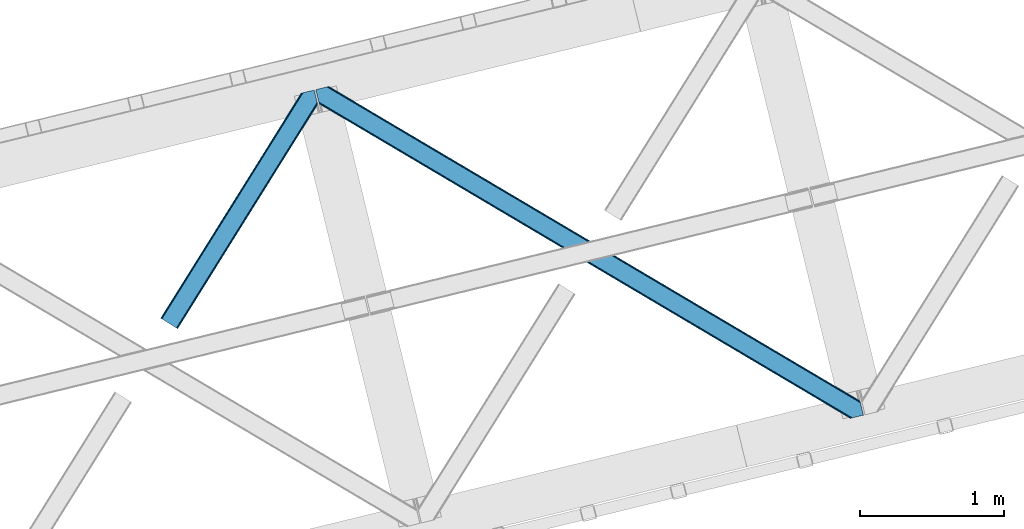
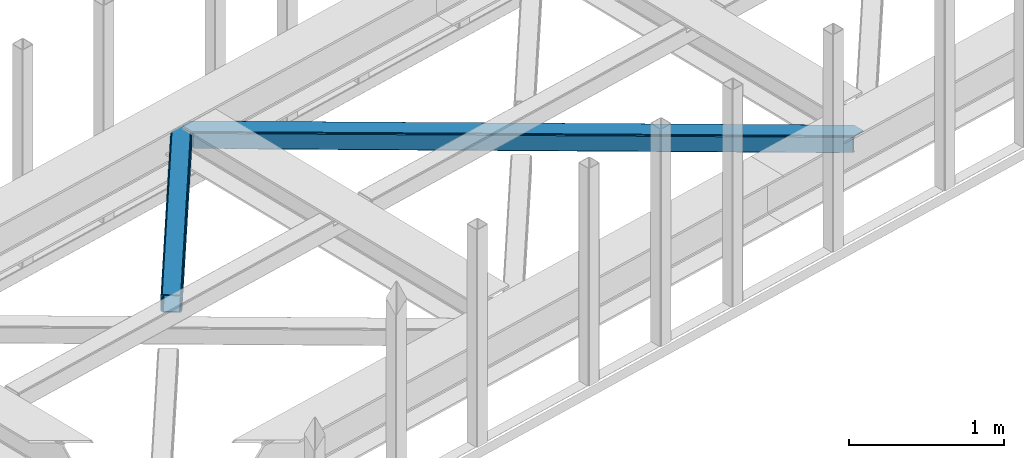
# One storey, part 43 of 67: 2 members.
"""IFC4 building model written with IfcOpenShell, lengths in millimetres."""

from ifc_helpers import new_model, entity, si_unit, converted_unit, derived_unit, direction, frame, origin, place, context, subcontext, project, spatial, triangles, type_object, element, save


model = new_model("IFC4")

# Units and contexts
model_context = context("Model", 3, precision=0.01, world=origin(), true_north=direction((6.12303176911189e-17, 1.0)))
plan_context = context("Plan", 3, precision=0.01, world=origin(), true_north=direction((6.12303176911189e-17, 1.0)))
body_context = subcontext(model_context, "Body", "Model", "MODEL_VIEW")
ifc_project = project(units=[si_unit("LENGTHUNIT", "METRE", prefix="MILLI"), si_unit("AREAUNIT", "SQUARE_METRE"), si_unit("VOLUMEUNIT", "CUBIC_METRE"), converted_unit("PLANEANGLEUNIT", "DEGREE", entity("IfcRatioMeasure", 0.0174532925199433), si_unit("PLANEANGLEUNIT", "RADIAN"), dimensions=[0, 0, 0, 0, 0, 0, 0]), si_unit("MASSUNIT", "GRAM", prefix="KILO"), derived_unit("MASSDENSITYUNIT", [(si_unit("MASSUNIT", "GRAM", prefix="KILO"), 1), (si_unit("LENGTHUNIT", "METRE"), -3)]), derived_unit("MOMENTOFINERTIAUNIT", [(si_unit("LENGTHUNIT", "METRE"), 4)]), si_unit("TIMEUNIT", "SECOND"), si_unit("FREQUENCYUNIT", "HERTZ"), si_unit("THERMODYNAMICTEMPERATUREUNIT", "DEGREE_CELSIUS"), derived_unit("THERMALTRANSMITTANCEUNIT", [(si_unit("MASSUNIT", "GRAM", prefix="KILO"), 1), (si_unit("THERMODYNAMICTEMPERATUREUNIT", "KELVIN"), -1), (si_unit("TIMEUNIT", "SECOND"), -3)]), derived_unit("VOLUMETRICFLOWRATEUNIT", [(si_unit("LENGTHUNIT", "METRE"), 3), (si_unit("TIMEUNIT", "SECOND"), -1)]), derived_unit("MASSFLOWRATEUNIT", [(si_unit("MASSUNIT", "GRAM", prefix="KILO"), 1), (si_unit("TIMEUNIT", "SECOND"), -1)]), derived_unit("ROTATIONALFREQUENCYUNIT", [(si_unit("TIMEUNIT", "SECOND"), -1)]), si_unit("ELECTRICCURRENTUNIT", "AMPERE"), si_unit("ELECTRICVOLTAGEUNIT", "VOLT"), si_unit("POWERUNIT", "WATT"), si_unit("FORCEUNIT", "NEWTON", prefix="KILO"), si_unit("ILLUMINANCEUNIT", "LUX"), si_unit("LUMINOUSFLUXUNIT", "LUMEN"), si_unit("LUMINOUSINTENSITYUNIT", "CANDELA"), derived_unit("USERDEFINED", [(si_unit("MASSUNIT", "GRAM", prefix="KILO"), -1), (si_unit("LENGTHUNIT", "METRE"), -2), (si_unit("TIMEUNIT", "SECOND"), 3), (si_unit("LUMINOUSFLUXUNIT", "LUMEN"), 1)]), derived_unit("LINEARVELOCITYUNIT", [(si_unit("LENGTHUNIT", "METRE"), 1), (si_unit("TIMEUNIT", "SECOND"), -1)]), si_unit("PRESSUREUNIT", "PASCAL"), derived_unit("USERDEFINED", [(si_unit("LENGTHUNIT", "METRE"), -2), (si_unit("MASSUNIT", "GRAM", prefix="KILO"), 1), (si_unit("TIMEUNIT", "SECOND"), -2)]), derived_unit("LINEARFORCEUNIT", [(si_unit("MASSUNIT", "GRAM", prefix="KILO"), 1), (si_unit("LENGTHUNIT", "METRE"), 1), (si_unit("TIMEUNIT", "SECOND"), -2), (si_unit("LENGTHUNIT", "METRE"), -1)]), derived_unit("PLANARFORCEUNIT", [(si_unit("MASSUNIT", "GRAM", prefix="KILO"), 1), (si_unit("LENGTHUNIT", "METRE"), 1), (si_unit("TIMEUNIT", "SECOND"), -2), (si_unit("LENGTHUNIT", "METRE"), -2)])], contexts=[model_context, plan_context])

# Site, building, storey
site_placement = place(None, origin())
site = spatial("IfcSite", under=ifc_project, at=site_placement, CompositionType="ELEMENT")
building_placement = place(site_placement, origin())
building = spatial("IfcBuilding", under=site, at=building_placement, CompositionType="ELEMENT")
storey_placement = place(building_placement, frame((0.0, 0.0, 19800.0)))
storey = spatial("IfcBuildingStorey", under=building, at=storey_placement, CompositionType="ELEMENT", Elevation=19800.0)

# Members
member_type_1 = type_object("IfcMemberType", PredefinedType="BRACE")
member_1_placement = place(storey_placement, frame((-25090.0569030762, 13275.8570983887, 3822.99993896484)))
element("IfcMember", 1, at=member_1_placement, inside=storey, type_object=member_type_1, ObjectType="Steel Horizontal Brace", PredefinedType="BRACE", context=body_context, shape_type="Tessellation", body=[
    triangles([(933.019793701173, 1535.69230957031, 0.0), (967.780462646486, 1393.09171142578, 0.0), (14.8456054687485, 64.8704589843746, 0.0), (103.916912841796, 9.2680389404286, 0.0), (928.803771972656, 1552.99125366211, 5.49966430664063), (928.943298339844, 1552.41687011719, 5.208984375), (930.803649902344, 1544.78710327148, 1.33247680664135), (971.996484374999, 1375.79276733398, 5.49966430664063), (971.856958007811, 1376.36715087891, 5.208984375), (969.996606445311, 1383.99691772461, 1.33247680664135), (972.210424804689, 1375.53813171387, 5.8531311035149), (972.422039794921, 1375.28349609375, 6.20659790039281), (928.913067626952, 1553.56912536621, 5.74383544921875), (972.724346923827, 1375.53813171387, 6.35310058593677), (929.029339599609, 1554.1772277832, 5.9996337890625), (973.026654052734, 1375.79276733398, 6.49960327148438), (929.143286132814, 1554.78416748047, 6.25543212890625), (929.254907226561, 1555.36203918457, 6.49960327148438), (4.34857177734375, 71.4223846435543, 5.12526855468968), (1.13248901367115, 73.4315643310547, 10.8039916992202), (973.359191894531, 1630.84347839355, 10.8039916992202), (976.914788818358, 1631.70970458984, 6.49960327148438), (9.16455688476708, 68.415591430663, 1.33247680664135), (971.508142089842, 1630.39118041992, 17.5012573242202), (0.0, 74.1361724853505, 17.5012573242202), (1081.10145263672, 1548.91708374023, 6.49960327148438), (1056.20762329101, 1651.03759460449, 6.49960327148438), (971.508142089842, 1630.39118041992, 122.499499511719), (0.0, 74.1361724853505, 122.499499511719), (973.359191894531, 1630.84347839355, 129.196765136719), (1.13248901367115, 73.4315643310547, 129.196765136719), (978.633288574219, 1632.12828369141, 134.87548828125), (4.34857177734375, 71.4223846435543, 134.87548828125), (986.525830078124, 1634.05258483887, 138.668280029298), (9.16455688476708, 68.415591430663, 138.668280029298), (995.83921508789, 1636.32221374512, 140.00075683594), (14.8456054687485, 64.8704589843746, 140.00075683594), (118.760192871094, 0.0, 17.5012573242202), (117.630029296874, 0.705770874023074, 10.8039916992202), (1085.14306640625, 1551.25066223144, 10.9783996582046), (1087.41734619141, 1552.56453552246, 13.4991760253906), (109.595635986327, 5.7205810546875, 1.33247680664135), (114.41162109375, 2.71495056152344, 5.12526855468968), (1087.56849975586, 1551.93550415039, 17.5012573242202), (1081.77583007812, 1575.70149536133, 140.00075683594), (1063.00720825195, 1652.69563293457, 140.00075683594), (103.916912841796, 9.2680389404286, 140.00075683594), (1083.99429931641, 1566.60670166016, 138.668280029298), (109.595635986327, 5.7205810546875, 138.668280029298), (1085.87325439453, 1558.89670715332, 134.87548828125), (114.41162109375, 2.71495056152344, 134.87548828125), (1087.12899169922, 1553.74469604492, 129.196765136719), (117.630029296874, 0.705770874023074, 129.196765136719), (1087.56849975586, 1551.93550415039, 122.499499511719), (118.760192871094, 0.0, 122.499499511719), (1082.53857421875, 1566.77297058105, 12.1248413085959), (1083.96406860352, 1566.72413635254, 13.4991760253906), (1077.85048828125, 1569.98556518555, 8.3320495605476), (1074.6483581543, 1577.50138549805, 6.99957275390625), (1056.69364013672, 1651.1561920166, 6.99957275390625), (1005.57350463867, 1638.69532470703, 6.99957275390625), (20.784777832032, 61.1625457763657, 6.99957275390625), (97.9754150390618, 12.9736267089829, 6.99957275390625), (108.47244873047, 6.42053833007776, 12.1248413085959), (111.690856933594, 4.41252136230469, 17.8035644531265), (1084.81052856445, 1563.2510925293, 17.8035644531265), (103.656463623047, 9.42733154296729, 8.3320495605476), (1085.25236206055, 1561.44190063477, 24.5008300781265), (112.823345947265, 3.70675048827979, 24.5008300781265), (983.093481445314, 1633.21542663574, 17.8035644531265), (981.24010620117, 1632.76429138184, 24.5008300781265), (7.0693359375, 69.7248138427731, 17.8035644531265), (5.93917236327979, 70.4305847167961, 24.5008300781265), (988.365252685548, 1634.50139465332, 12.1248413085959), (10.2877441406235, 67.7156341552727, 12.1248413085959), (996.262445068358, 1636.42569580078, 8.3320495605476), (15.1037292480469, 64.7100036621086, 8.3320495605476), (981.24010620117, 1632.76429138184, 115.499926757813), (5.93917236327979, 70.4305847167961, 115.499926757813), (996.262445068358, 1636.42569580078, 131.668707275392), (1005.57350463867, 1638.69532470703, 133.001184082033), (1063.00720825195, 1652.69563293457, 133.001184082033), (988.365252685548, 1634.50139465332, 127.873590087893), (983.093481445314, 1633.21542663574, 122.197192382813), (20.784777832032, 61.1625457763657, 133.001184082033), (15.1037292480469, 64.7100036621086, 131.668707275392), (10.2877441406235, 67.7156341552727, 127.873590087893), (7.0693359375, 69.7248138427731, 122.197192382813), (108.47244873047, 6.42053833007776, 127.873590087893), (111.690856933594, 4.41252136230469, 122.197192382813), (112.823345947265, 3.70675048827979, 115.499926757813), (97.9754150390618, 12.9736267089829, 133.001184082033), (103.656463623047, 9.42733154296729, 131.668707275392), (1085.25236206055, 1561.44190063477, 115.499926757813), (1084.81052856445, 1563.2510925293, 122.197192382813), (1083.55479125976, 1568.40310363769, 127.873590087893), (1081.67583618164, 1576.11309814453, 131.668707275392), (1079.45969238281, 1585.20905456543, 133.001184082033)], [[1, 2, 3], [4, 3, 2], [1, 5, 2], [6, 5, 1], [1, 7, 6], [2, 5, 8], [8, 9, 2], [10, 2, 9], [11, 8, 5], [12, 11, 13], [14, 12, 15], [16, 14, 17], [17, 18, 16], [15, 17, 14], [13, 15, 12], [5, 13, 11], [17, 19, 18], [19, 17, 15], [13, 19, 15], [19, 13, 5], [5, 6, 19], [20, 21, 18], [18, 19, 20], [21, 22, 18], [19, 6, 7], [7, 1, 23], [3, 23, 1], [7, 23, 19], [24, 21, 20], [20, 25, 24], [18, 26, 16], [26, 18, 22], [27, 26, 22], [28, 24, 25], [25, 29, 28], [30, 28, 31], [29, 31, 28], [32, 30, 33], [31, 33, 30], [34, 32, 35], [33, 35, 32], [36, 34, 37], [35, 37, 34], [38, 39, 40], [40, 41, 38], [42, 10, 9], [39, 12, 16], [16, 40, 39], [16, 26, 40], [9, 39, 43], [9, 12, 39], [9, 43, 42], [2, 10, 4], [42, 4, 10], [41, 44, 38], [45, 36, 37], [36, 45, 46], [37, 47, 45], [48, 45, 47], [47, 49, 48], [50, 48, 49], [49, 51, 50], [52, 50, 51], [51, 53, 52], [54, 52, 53], [53, 55, 54], [44, 54, 38], [55, 38, 54], [56, 40, 26], [41, 40, 56], [56, 57, 41], [58, 26, 59], [26, 58, 56], [60, 59, 26], [59, 61, 62], [61, 59, 60], [62, 63, 59], [64, 65, 66], [66, 57, 64], [58, 59, 63], [63, 67, 58], [56, 58, 67], [67, 64, 56], [57, 56, 64], [68, 66, 65], [65, 69, 68], [70, 71, 72], [73, 72, 71], [74, 70, 75], [72, 75, 70], [76, 74, 77], [75, 77, 74], [61, 76, 62], [77, 62, 76], [71, 78, 73], [79, 73, 78], [34, 36, 80], [46, 81, 36], [81, 46, 82], [81, 80, 36], [83, 34, 80], [83, 32, 34], [32, 84, 30], [84, 32, 83], [28, 84, 78], [84, 28, 30], [61, 22, 76], [70, 74, 22], [74, 76, 22], [61, 60, 22], [71, 70, 24], [21, 24, 70], [28, 71, 24], [71, 28, 78], [70, 22, 21], [80, 81, 85], [85, 86, 80], [83, 80, 86], [86, 87, 83], [84, 83, 87], [87, 88, 84], [78, 84, 88], [88, 79, 78], [53, 89, 90], [91, 38, 55], [53, 90, 55], [53, 51, 89], [90, 91, 55], [89, 51, 49], [92, 47, 37], [47, 93, 49], [93, 47, 92], [93, 89, 49], [39, 64, 43], [69, 38, 91], [38, 65, 39], [65, 38, 69], [39, 65, 64], [4, 63, 3], [42, 43, 64], [64, 67, 42], [67, 63, 4], [4, 42, 67], [87, 35, 33], [37, 85, 92], [37, 86, 85], [86, 37, 35], [87, 86, 35], [79, 29, 25], [31, 88, 87], [33, 31, 87], [88, 31, 29], [79, 88, 29], [23, 75, 19], [3, 63, 62], [62, 77, 3], [77, 75, 23], [23, 3, 77], [20, 19, 75], [25, 73, 79], [72, 25, 20], [25, 72, 73], [72, 20, 75], [66, 41, 57], [54, 44, 68], [44, 66, 68], [68, 94, 54], [44, 41, 66], [95, 54, 94], [52, 54, 95], [50, 95, 96], [95, 50, 52], [96, 48, 50], [97, 48, 96], [97, 98, 45], [97, 45, 48], [98, 46, 45], [98, 82, 46], [81, 98, 85], [81, 82, 98], [92, 85, 98], [95, 94, 90], [91, 90, 94], [96, 95, 89], [90, 89, 95], [97, 96, 93], [89, 93, 96], [98, 97, 92], [93, 92, 97], [94, 68, 69], [69, 91, 94]]),
])
member_type_2 = type_object("IfcMemberType", PredefinedType="BRACE")
member_2_placement = place(storey_placement, frame((-24015.3899414063, 12655.9240081787, 3822.99993896484)))
element("IfcMember", 2, at=member_2_placement, inside=storey, type_object=member_type_2, ObjectType="Steel Horizontal Brace", PredefinedType="BRACE", context=body_context, shape_type="Tessellation", body=[
    triangles([(3167.12528686523, 476.930191040039, 17.5012573242202), (3764.84926757812, 123.064581298828, 122.499499511719), (3764.84926757812, 123.064581298828, 17.5012573242202), (2547.33288574219, 843.861282348633, 17.5012573242202), (1927.54048461914, 1210.79353637695, 17.5012573242202), (91.5013916015632, 2297.7748626709, 122.499499511719), (687.9580078125, 1944.65804443359, 17.5012573242202), (91.5013916015632, 2297.7748626709, 17.5012573242202), (1307.7480834961, 1577.72579040527, 17.5012573242202), (3770.64193725586, 99.297427368163, 140.00075683594), (3768.42346801758, 108.393383789062, 138.668280029298), (76.4813781738267, 2294.11345825195, 138.668280029298), (67.167993164061, 2291.8438293457, 140.00075683594), (3766.54451293945, 116.103378295898, 134.87548828125), (84.3739196777351, 2296.03775939941, 134.87548828125), (3765.28877563477, 121.255389404296, 129.196765136719), (89.6503417968743, 2297.32372741699, 129.196765136719), (3722.24024047852, 5.93103332519422, 140.00075683594), (18.7662963867188, 2198.47743530273, 140.00075683594), (3789.41055908203, 22.304452514647, 140.00075683594), (0.0, 2275.47041015625, 140.00075683594), (3697.90916748047, 0.0, 122.499499511719), (3699.76021728515, 0.451135253904795, 129.196765136719), (24.1194580078118, 2176.5194732666, 129.196765136719), (24.5612915039055, 2174.71028137207, 122.499499511719), (3705.03431396484, 1.73710327148365, 134.87548828125), (22.8637207031243, 2181.671484375, 134.87548828125), (3712.9291809082, 3.66024169921729, 138.668280029298), (20.9847656249985, 2189.38147888184, 138.668280029298), (1862.08401489258, 1086.85342712402, 17.5012573242202), (2481.93687744141, 719.881640624999, 17.5012573242202), (3101.79671630859, 352.912179565428, 17.5012573242202), (3697.90916748047, 0.0, 17.5012573242202), (1242.22417602539, 1453.82288818359, 17.5012573242202), (622.368988037109, 1820.79467468262, 17.5012573242202), (24.5612915039055, 2174.71028137207, 17.5012573242202), (74.641955566407, 2293.66581115723, 127.873590087893), (66.7470886230476, 2291.74151000977, 131.668707275392), (79.9160522460952, 2294.9517791748, 122.197192382813), (57.433703613282, 2289.47071838379, 133.001184082033), (0.0, 2275.47041015625, 133.001184082033), (81.7671020507805, 2295.40175170898, 115.499926757813), (81.7671020507805, 2295.40175170898, 24.5008300781265), (79.9160522460952, 2294.9517791748, 17.8035644531265), (89.5619750976548, 2297.30279846191, 10.8156188964858), (89.4689575195298, 2297.27954406738, 10.4993591308594), (74.1140808105483, 2293.53674926758, 12.4271484375022), (72.0351379394524, 2293.0298034668, 10.4993591308594), (1922.1942993164, 1205.8275604248, 24.5008300781265), (3767.16540527344, 113.558184814452, 115.499926757813), (2545.10744018555, 837.044256591797, 24.5008300781265), (3168.02755737305, 468.263278198241, 24.5008300781265), (3767.16540527344, 113.558184814452, 24.5008300781265), (1299.27418212891, 1574.60853881836, 24.5008300781265), (676.358715820312, 1943.39067993164, 24.5008300781265), (3767.60723876953, 111.748992919922, 122.197192382813), (3768.86297607422, 106.596981811523, 127.873590087893), (3770.74193115234, 98.8858245849606, 131.668707275392), (3772.95807495117, 89.7910308837891, 133.001184082033), (3767.69560546875, 111.385061645507, 17.8686767578147), (3767.80257568359, 110.943228149414, 16.5199218750022), (3764.85624389648, 123.027374267578, 16.5199218750022), (3789.41055908203, 22.304452514647, 133.001184082033), (3731.9745300293, 8.30298156738172, 133.001184082033), (16.4501586914048, 2207.98383178711, 133.001184082033), (162.736578369142, 2253.90428466797, 10.4993591308594), (166.88748779297, 2236.87509155273, 10.4993591308594), (3722.66114501953, 6.03335266113208, 131.668707275392), (18.6663024902336, 2198.88787536621, 131.668707275392), (3714.76627807617, 4.10905151367115, 127.873590087893), (20.5452575683594, 2191.17788085938, 127.873590087893), (3709.49450683594, 2.82424621581958, 122.197192382813), (21.8033203125015, 2186.02586975098, 122.197192382813), (3707.6411315918, 2.3719482421875, 115.499926757813), (22.2428283691406, 2184.21667785644, 115.499926757813), (3114.18665771484, 353.712130737304, 24.5008300781265), (3707.6411315918, 2.3719482421875, 24.5008300781265), (2491.11771240235, 722.582638549804, 24.5008300781265), (1868.0510925293, 1091.4531463623, 24.5008300781265), (621.917852783205, 1829.19532470703, 24.5008300781265), (22.2428283691406, 2184.21667785644, 24.5008300781265), (1244.9867980957, 1460.32481689453, 24.5008300781265), (3709.49450683594, 2.82424621581958, 17.8035644531265), (3700.13228759765, 0.541827392577034, 10.8691040039084), (3700.58342285156, 0.651123046875, 9.52034912109593), (3714.76627807617, 4.10905151367115, 12.1248413085959), (3719.39390258789, 5.23688964843677, 9.52034912109593), (21.7823913574211, 2186.11074829102, 17.817517089843), (21.7591369628899, 2186.20144042969, 17.5012573242202), (32.1375732421875, 2171.84650268555, 10.8179443359368), (28.3471069335938, 2188.73849487305, 10.4993591308594), (27.0099792480469, 2187.35020751953, 12.1248413085959), (32.4980163574219, 2171.71046447754, 10.4993591308594), (203.964294433594, 2084.76809692383, 10.4993591308594), (208.115203857422, 2067.73890380859, 10.4993591308594), (164.09696044922, 2252.54739074707, 9.49942016601563), (168.582733154297, 2234.14386291504, 9.49942016601563), (168.164154052734, 2234.81707763672, 9.74591674804833), (163.769073486328, 2252.87527770996, 9.74126586914281), (167.733947753906, 2235.50889587402, 9.9993896484375), (163.415606689454, 2253.22525634766, 9.9993896484375), (167.306066894533, 2236.20187683105, 10.2528625488303), (163.064465332031, 2253.57639770508, 10.2598388671868), (209.161651611328, 2067.67146606445, 9.49942016601563), (209.136071777342, 2067.46682739258, 9.88311767578125), (204.678204345702, 2085.44247436523, 9.8528869628899), (208.801208496094, 2067.5551940918, 10.0831054687515), (204.682855224608, 2084.81111755371, 10.2063537597678), (208.447741699219, 2067.65053710938, 10.2993713378928), (204.322412109374, 2084.78902587891, 10.3528564453118), (204.675878906251, 2086.07383117676, 9.49942016601563), (3763.57492675781, 109.725860595703, 12.1248413085959), (3758.56825561524, 124.970278930663, 10.8714294433594), (3757.06602172851, 125.435366821288, 9.52034912109593), (3761.54481811524, 107.063232421875, 9.52034912109593), (3585.92530517578, 211.033630371094, 9.52034912109593), (3581.44650878906, 229.405764770507, 9.52034912109593), (3585.50672607422, 211.133624267577, 9.44360961914208), (3581.04653320312, 229.55343017578, 9.37384643554833), (3580.64655761719, 229.699932861327, 9.22734375000073), (3580.53493652344, 229.532501220703, 8.87387695312646), (3585.4578918457, 210.476687622069, 9.13897705078125), (3580.42796630859, 229.365069580077, 8.52041015625218), (3585.40673217773, 209.805798339843, 8.82736816406396), (3585.35557250976, 209.147698974608, 8.52041015625218), (3164.51381835937, 472.51883239746, 5.12526855468968), (3581.30233154297, 225.771102905273, 5.12526855468968), (3166.44858398438, 475.783749389648, 10.8039916992202), (687.281304931639, 1943.5116027832, 10.8039916992202), (685.34653930664, 1940.24784851074, 5.12526855468968), (165.152709960938, 2248.2150970459, 5.12526855468968), (682.456018066405, 1935.36210021973, 1.33247680664135), (167.031665039063, 2240.50393981933, 1.33247680664135), (679.044598388671, 1929.59966125488, 0.0), (169.247808837892, 2231.40914611816, 0.0), (3583.18361206055, 218.061108398437, 1.33247680664135), (3585.39975585938, 208.965151977538, 0.0), (3158.2118774414, 461.8706451416, 0.0), (3161.62329711914, 467.633084106445, 1.33247680664135), (2546.65618286133, 842.716003417969, 10.8039916992202), (1926.86378173828, 1209.64709472656, 10.8039916992202), (1307.07138061523, 1576.57934875488, 10.8039916992202), (2544.72141723633, 839.451086425781, 5.12526855468968), (1924.92901611328, 1206.3833404541, 5.12526855468968), (1305.13661499024, 1573.31443176269, 5.12526855468968), (2541.83089599609, 834.565338134766, 1.33247680664135), (1922.03849487305, 1201.49759216308, 1.33247680664135), (1302.24609375, 1568.42984619141, 1.33247680664135), (2538.41947631836, 828.802899169921, 0.0), (1918.62707519531, 1195.73515319824, 0.0), (1298.83467407227, 1562.66740722656, 0.0), (3620.16042480469, 66.3657165527329, 0.0), (3110.71245117188, 367.97056274414, 0.0), (2490.85726318359, 734.941186523436, 0.0), (1870.99742431641, 1101.91181030273, 0.0), (631.284722900389, 1835.85305786133, 0.0), (1251.13758544922, 1468.8812713623, 0.0), (204.008477783202, 2088.80854797363, 0.0), (3167.34852905274, 467.116836547852, 17.8035644531265), (3165.41608886719, 463.853082275389, 12.1248413085959), (673.749572753906, 1938.98048400879, 12.1248413085959), (675.682012939455, 1942.24423828125, 17.8035644531265), (670.85672607422, 1934.09473571777, 8.3320495605476), (169.396636962891, 2230.80104370117, 8.81806640624927), (171.566271972657, 2221.90274963379, 6.99957275390625), (3159.11182250977, 453.204895019531, 6.99957275390625), (3587.71821899414, 199.458755493164, 6.99957275390625), (3585.50672607422, 208.524481201172, 8.42274169921802), (3162.5232421875, 458.967333984374, 8.3320495605476), (667.442980957032, 1928.3311340332, 6.99957275390625), (2536.19403076172, 821.985873413085, 6.99957275390625), (2539.60545043945, 827.748312377929, 8.3320495605476), (1913.27856445313, 1190.76801452637, 6.99957275390625), (1916.68998413086, 1196.53045349121, 8.3320495605476), (1290.36077270508, 1559.54899291992, 6.99957275390625), (1293.76986694336, 1565.31259460449, 8.3320495605476), (2542.49597167969, 832.634060668945, 12.1248413085959), (1919.58283081055, 1201.41620178223, 12.1248413085959), (1296.66271362305, 1570.19718017578, 12.1248413085959), (2544.43073730469, 835.898977661132, 17.8035644531265), (1921.51527099609, 1204.68111877441, 17.8035644531265), (1298.59515380859, 1573.46209716797, 17.8035644531265), (201.692340087891, 2098.31610717773, 6.99957275390625), (203.861975097658, 2089.41665039063, 8.81806640624927), (206.226947021485, 2079.71375427246, 1.33247680664135), (208.105902099611, 2072.00375976562, 5.12526855468968), (2500.03577270508, 737.642184448241, 6.99957275390625), (3123.10239257813, 368.771676635741, 6.99957275390625), (1876.96682739258, 1106.51269226074, 6.99957275390625), (3617.84196166992, 75.8721130371086, 6.99957275390625), (630.833587646484, 1844.25370788574, 6.99957275390625), (1253.90020751953, 1475.38320007324, 6.99957275390625), (3119.69097290039, 363.009237670898, 8.3320495605476), (3620.56040039063, 65.0390533447262, 8.90410766601781), (3620.2046081543, 66.183169555663, 8.52041015625218), (3116.7981262207, 358.123489379883, 12.1248413085959), (3621.05106811523, 64.3204925537102, 9.1087463378899), (3621.5487121582, 63.5914672851559, 9.31571044922021), (3622.04170532227, 62.8729064941399, 9.52034912109593), (3620.05345458984, 66.8063873291012, 8.42274169921802), (624.529321289061, 1833.60552062988, 12.1248413085959), (627.422167968751, 1838.4912689209, 8.3320495605476), (622.596881103516, 1830.34176635742, 17.8035644531265), (3114.86568603515, 354.858572387695, 17.8035644531265), (2491.79906616211, 723.730242919921, 17.8035644531265), (1868.73012084961, 1092.59958801269, 17.8035644531265), (1245.66350097656, 1461.47125854492, 17.8035644531265), (2493.72685546875, 726.992834472656, 12.1248413085959), (1870.66256103515, 1095.86450500488, 12.1248413085959), (1247.59594116211, 1464.73501281738, 12.1248413085959), (2496.61970214844, 731.878582763671, 8.3320495605476), (1873.55540771484, 1100.74909057617, 8.3320495605476), (1250.4887878418, 1469.6207611084, 8.3320495605476), (3102.47574462891, 354.057458496092, 10.8039916992202), (624.980456542969, 1825.20487060547, 5.12526855468968), (623.048016357421, 1821.93995361328, 10.8039916992202), (3626.51817626953, 44.5007720947251, 9.52034912109593), (3104.40818481445, 357.32237548828, 5.12526855468968), (3624.25552368164, 49.5597656249993, 5.12526855468968), (3625.13221435547, 45.9657989501939, 8.52041015625218), (3625.82286987305, 45.2332855224595, 9.02037963867406), (3622.37656860351, 57.2697601318359, 1.33247680664135), (3107.30103149414, 362.208123779295, 1.33247680664135), (627.873303222656, 1830.09061889648, 1.33247680664135), (2487.44119262695, 729.177584838866, 1.33247680664135), (1867.58600463867, 1096.14937133789, 1.33247680664135), (1247.72849121094, 1463.11883239746, 1.33247680664135), (2484.55299682617, 724.292999267578, 5.12526855468968), (1864.69315795898, 1091.26362304687, 5.12526855468968), (1244.83564453125, 1458.23308410644, 5.12526855468968), (2482.62055664062, 721.029244995116, 10.8039916992202), (1862.76071777344, 1087.99870605469, 10.8039916992202), (1242.9032043457, 1454.96932983398, 10.8039916992202)], [[1, 2, 3], [2, 1, 4], [2, 5, 6], [5, 2, 4], [7, 8, 6], [9, 6, 5], [6, 9, 7], [10, 11, 12], [12, 13, 10], [11, 14, 15], [15, 12, 11], [14, 16, 17], [17, 15, 14], [16, 2, 6], [6, 17, 16], [18, 10, 19], [18, 20, 10], [13, 19, 10], [21, 19, 13], [22, 23, 24], [24, 25, 22], [23, 26, 27], [27, 24, 23], [26, 28, 29], [29, 27, 26], [28, 18, 19], [19, 29, 28], [30, 22, 25], [22, 31, 32], [30, 31, 22], [32, 33, 22], [34, 25, 35], [25, 34, 30], [36, 35, 25], [37, 38, 12], [15, 37, 12], [15, 17, 39], [37, 15, 39], [39, 17, 6], [38, 13, 12], [21, 40, 41], [21, 13, 40], [38, 40, 13], [39, 6, 42], [43, 8, 44], [6, 43, 42], [8, 45, 44], [6, 8, 43], [46, 44, 45], [46, 47, 44], [46, 48, 47], [49, 50, 42], [50, 51, 52], [49, 51, 50], [52, 53, 50], [54, 42, 55], [42, 54, 49], [43, 55, 42], [50, 56, 42], [39, 42, 56], [56, 57, 39], [37, 39, 57], [57, 58, 37], [38, 37, 58], [58, 59, 38], [40, 38, 59], [57, 14, 11], [59, 58, 10], [58, 57, 11], [60, 61, 62], [63, 59, 20], [10, 20, 59], [58, 11, 10], [60, 3, 53], [2, 50, 53], [53, 3, 2], [60, 62, 3], [2, 56, 50], [56, 14, 57], [14, 56, 16], [2, 16, 56], [59, 64, 65], [64, 59, 63], [65, 40, 59], [41, 40, 65], [66, 67, 46], [48, 46, 67], [64, 68, 65], [69, 65, 68], [68, 70, 69], [71, 69, 70], [70, 72, 71], [73, 71, 72], [72, 74, 73], [75, 73, 74], [76, 74, 77], [74, 76, 78], [74, 79, 75], [79, 74, 78], [80, 81, 75], [82, 75, 79], [75, 82, 80], [70, 68, 28], [26, 70, 28], [26, 23, 72], [70, 26, 72], [72, 23, 22], [68, 18, 28], [20, 64, 63], [20, 18, 64], [68, 64, 18], [72, 22, 74], [77, 33, 83], [22, 77, 74], [33, 84, 83], [22, 33, 77], [85, 83, 84], [86, 83, 85], [87, 86, 85], [73, 75, 25], [25, 24, 73], [27, 73, 24], [73, 27, 71], [25, 81, 36], [88, 89, 36], [36, 81, 88], [75, 81, 25], [69, 29, 19], [21, 65, 19], [41, 65, 21], [69, 71, 29], [29, 71, 27], [65, 69, 19], [90, 91, 92], [90, 93, 91], [92, 36, 90], [89, 36, 92], [94, 95, 93], [93, 91, 94], [96, 97, 98], [98, 99, 96], [99, 98, 100], [100, 101, 99], [101, 100, 102], [102, 103, 101], [103, 102, 67], [67, 66, 103], [104, 105, 106], [105, 107, 108], [108, 107, 109], [110, 109, 95], [95, 94, 110], [109, 110, 108], [108, 106, 105], [106, 111, 104], [62, 112, 113], [112, 62, 61], [112, 114, 113], [112, 115, 114], [114, 115, 116], [116, 117, 114], [118, 119, 117], [120, 119, 118], [121, 120, 122], [123, 121, 124], [124, 125, 123], [122, 124, 121], [118, 122, 120], [117, 116, 118], [1, 3, 113], [3, 62, 113], [120, 121, 126], [123, 126, 121], [123, 127, 126], [128, 113, 117], [117, 126, 128], [117, 119, 126], [120, 126, 119], [113, 114, 117], [45, 129, 66], [129, 130, 131], [131, 96, 129], [129, 99, 101], [99, 129, 96], [129, 103, 66], [103, 129, 101], [129, 45, 8], [8, 7, 129], [66, 46, 45], [130, 132, 133], [133, 131, 130], [132, 134, 135], [135, 133, 132], [136, 137, 138], [138, 139, 136], [127, 136, 139], [139, 126, 127], [113, 128, 1], [1, 128, 140], [140, 4, 1], [4, 140, 5], [141, 5, 140], [5, 141, 142], [142, 9, 5], [9, 142, 129], [129, 7, 9], [128, 126, 140], [143, 140, 126], [140, 143, 141], [144, 141, 143], [141, 144, 145], [145, 142, 141], [142, 145, 130], [130, 129, 142], [126, 139, 146], [146, 143, 126], [143, 146, 147], [147, 144, 143], [144, 147, 145], [148, 145, 147], [145, 148, 130], [132, 130, 148], [139, 138, 146], [149, 146, 138], [146, 149, 147], [150, 147, 149], [147, 150, 148], [151, 148, 150], [148, 151, 134], [134, 132, 148], [137, 152, 153], [138, 153, 154], [153, 138, 137], [149, 155, 150], [154, 149, 138], [149, 154, 155], [156, 134, 151], [150, 157, 151], [157, 150, 155], [157, 156, 151], [158, 134, 156], [135, 134, 158], [159, 160, 112], [112, 61, 159], [159, 60, 53], [161, 162, 44], [98, 163, 100], [98, 97, 163], [163, 102, 100], [163, 67, 102], [97, 164, 163], [161, 47, 67], [67, 163, 161], [47, 48, 67], [163, 164, 165], [166, 167, 168], [160, 118, 116], [116, 112, 160], [116, 115, 112], [169, 168, 125], [125, 160, 169], [124, 122, 160], [122, 118, 160], [160, 125, 124], [168, 169, 166], [165, 170, 163], [44, 47, 161], [162, 55, 43], [43, 44, 162], [53, 52, 159], [61, 60, 159], [166, 169, 171], [172, 171, 169], [171, 172, 173], [174, 173, 172], [173, 174, 175], [176, 175, 174], [175, 176, 163], [163, 170, 175], [169, 160, 177], [177, 172, 169], [172, 177, 178], [178, 174, 172], [174, 178, 179], [179, 176, 174], [176, 179, 163], [161, 163, 179], [160, 159, 177], [180, 177, 159], [177, 180, 178], [181, 178, 180], [178, 181, 179], [182, 179, 181], [179, 182, 162], [162, 161, 179], [159, 52, 180], [51, 180, 52], [180, 51, 49], [49, 181, 180], [181, 49, 182], [54, 182, 49], [182, 54, 162], [55, 162, 54], [97, 131, 133], [135, 97, 133], [165, 164, 135], [165, 135, 183], [131, 97, 96], [135, 164, 97], [183, 158, 184], [158, 185, 111], [158, 183, 135], [186, 111, 185], [158, 111, 184], [186, 104, 111], [187, 188, 166], [166, 171, 187], [171, 189, 187], [189, 171, 173], [188, 167, 166], [188, 190, 167], [170, 191, 175], [191, 170, 183], [165, 183, 170], [192, 175, 191], [173, 192, 189], [175, 192, 173], [193, 194, 195], [196, 197, 194], [196, 198, 197], [196, 199, 198], [194, 193, 196], [195, 200, 193], [86, 87, 199], [199, 196, 86], [193, 200, 190], [191, 183, 184], [201, 108, 110], [110, 94, 201], [94, 92, 201], [94, 91, 92], [202, 106, 108], [202, 111, 106], [202, 184, 111], [108, 201, 202], [203, 201, 92], [92, 89, 203], [203, 88, 81], [81, 80, 203], [89, 88, 203], [184, 202, 191], [190, 188, 193], [83, 86, 196], [196, 204, 83], [77, 83, 204], [204, 76, 77], [76, 204, 205], [205, 78, 76], [78, 205, 206], [206, 79, 78], [79, 206, 82], [207, 82, 206], [82, 207, 80], [203, 80, 207], [204, 196, 205], [208, 205, 196], [205, 208, 209], [209, 206, 205], [206, 209, 210], [210, 207, 206], [207, 210, 201], [201, 203, 207], [196, 193, 211], [211, 208, 196], [208, 211, 212], [212, 209, 208], [209, 212, 210], [213, 210, 212], [210, 213, 201], [202, 201, 213], [193, 188, 211], [187, 211, 188], [211, 187, 189], [189, 212, 211], [212, 189, 213], [192, 213, 189], [213, 192, 191], [191, 202, 213], [214, 84, 33], [35, 36, 90], [215, 105, 104], [216, 90, 95], [95, 215, 216], [95, 107, 215], [104, 186, 215], [84, 214, 217], [214, 218, 219], [219, 220, 214], [221, 217, 214], [214, 220, 221], [217, 85, 84], [222, 219, 218], [218, 223, 222], [152, 222, 223], [223, 153, 152], [156, 224, 185], [185, 158, 156], [224, 215, 186], [186, 185, 224], [90, 216, 35], [33, 32, 214], [153, 223, 154], [225, 154, 223], [154, 225, 155], [226, 155, 225], [155, 226, 157], [227, 157, 226], [157, 227, 224], [224, 156, 157], [223, 218, 228], [228, 225, 223], [225, 228, 229], [229, 226, 225], [226, 229, 230], [230, 227, 226], [227, 230, 224], [215, 224, 230], [218, 214, 228], [231, 228, 214], [228, 231, 229], [232, 229, 231], [229, 232, 230], [233, 230, 232], [230, 233, 215], [216, 215, 233], [214, 32, 31], [31, 231, 214], [231, 31, 30], [30, 232, 231], [232, 30, 34], [34, 233, 232], [233, 34, 35], [35, 216, 233], [137, 167, 190], [125, 127, 123], [137, 125, 167], [125, 136, 127], [125, 137, 136], [152, 137, 190], [195, 152, 190], [219, 195, 220], [195, 222, 152], [195, 219, 222], [220, 195, 194], [221, 194, 197], [221, 197, 198], [217, 198, 199], [87, 85, 199], [217, 199, 85]]),
])

save(model, "model.ifc")
